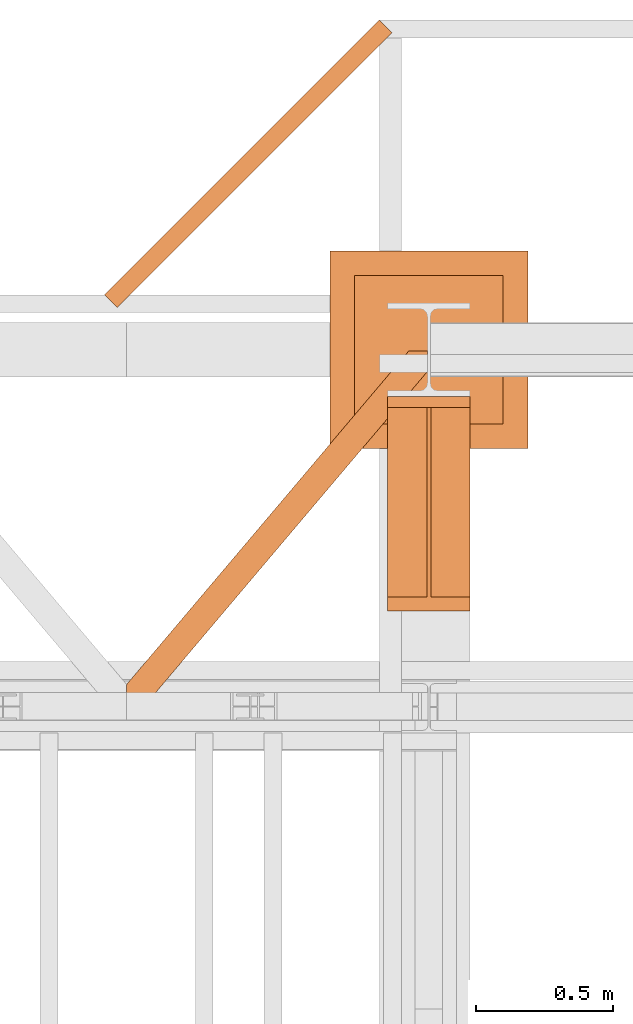
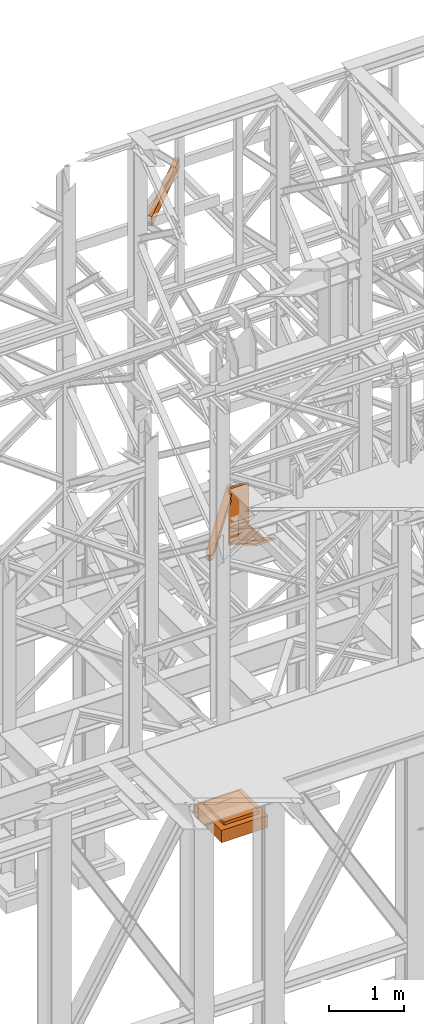
# One storey, part 193 of 208: 4 proxies.
"""IFC2X3 building model written with IfcOpenShell, lengths in millimetres."""

from ifc_helpers import new_model, entity, si_unit, converted_unit, frame, origin, origin_with_axes, place, context, subcontext, project, spatial, faceted_brep, element, save


model = new_model("IFC2X3")

# Units and contexts
model_context = context("Model", 3, precision=1e-05, world=origin())
plan_context = context("Plan", 3, precision=1e-05, world=origin())
body_context = subcontext(model_context, "Body", "Model", "MODEL_VIEW")
ifc_project = project(units=[si_unit("LENGTHUNIT", "METRE", prefix="MILLI"), converted_unit("PLANEANGLEUNIT", "DEGREE", entity("IfcPlaneAngleMeasure", 0.0174532925199433), si_unit("PLANEANGLEUNIT", "RADIAN"), dimensions=[0, 0, 0, 0, 0, 0, 0]), si_unit("AREAUNIT", "SQUARE_METRE"), si_unit("VOLUMEUNIT", "CUBIC_METRE")], contexts=[model_context, plan_context])

# Building, storey
building_placement = place(None, origin())
building = spatial("IfcBuilding", under=ifc_project, at=building_placement, CompositionType="COMPLEX")
storey_placement = place(building_placement, origin_with_axes())
storey = spatial("IfcBuildingStorey", under=building, at=storey_placement, Name="Geschoss", CompositionType="ELEMENT")

# Proxies
proxy_1_placement = place(storey_placement, frame((5343.254974489131, -13412.43639531565, 4367.230005364415), z_axis=(0.0, 0.0, 1.0), x_axis=(1.0, 0.0, 0.0)))
element("IfcBuildingElementProxy", 1, at=proxy_1_placement, inside=storey, context=body_context, shape_type="Brep", body=[
    faceted_brep([(0.01000000000021828, 739.8719999999976, 18.61000000000058), (0.01000000000021828, 0.00999999999839929, 445.7700000000004), (300.0100000000002, 0.00999999999839929, 445.7700000000004), (300.0100000000002, 739.8719999999976, 18.61000000000058), (0.01000000000021828, 0.00999999999839929, 445.7700000000004), (0.01000000000021828, 50.06599999999889, 445.7710000000006), (142.5100000000002, 50.06599999999708, 445.7710000000006), (142.5100000000002, 739.8719999999976, 445.7700000000004), (157.5100000000002, 739.8719999999976, 445.7700000000004), (157.5100000000002, 50.06599999999708, 445.7710000000006), (300.0100000000002, 50.06599999999708, 445.7710000000006), (300.0100000000002, 0.00999999999839929, 445.7700000000004), (0.01000000000021828, 50.06599999999889, 445.7710000000006), (0.01000000000021828, 739.8719999999976, 47.51000000000022), (142.5100000000002, 739.8719999999976, 47.51000000000022), (142.5100000000002, 50.06599999999708, 445.7710000000006), (157.5100000000002, 739.8719999999976, 47.51000000000022), (300.0100000000002, 739.8719999999976, 47.51000000000022), (300.0100000000002, 50.06599999999708, 445.7710000000006), (157.5100000000002, 50.06599999999708, 445.7710000000006), (0.01000000000021828, 739.8719999999976, 18.61000000000058), (0.01000000000021828, 739.8719999999976, 0.01000000000021828), (0.01000000000021828, 779.8719999999976, 0.01000000000021828), (0.01000000000021828, 779.8719999999976, 917.7700000000013), (0.01000000000021828, 739.8719999999976, 917.7700000000013), (0.01000000000021828, 739.8719999999976, 47.51000000000022), (0.01000000000021828, 50.06599999999889, 445.7710000000006), (0.01000000000021828, 0.00999999999839929, 445.7700000000004), (300.0100000000002, 779.8719999999976, 917.7700000000013), (300.0100000000002, 779.8719999999976, 0.01000000000021828), (300.0100000000002, 739.8719999999976, 0.01000000000021828), (300.0100000000002, 739.8719999999976, 18.61000000000058), (300.0100000000002, 0.00999999999839929, 445.7700000000004), (300.0100000000002, 50.06599999999708, 445.7710000000006), (300.0100000000002, 739.8719999999976, 47.51000000000022), (300.0100000000002, 739.8719999999976, 917.7700000000013), (300.0100000000002, 779.8719999999976, 917.7700000000013), (300.0100000000002, 739.8719999999976, 917.7700000000013), (0.01000000000021828, 739.8719999999976, 917.7700000000013), (0.01000000000021828, 779.8719999999976, 917.7700000000013), (300.0100000000002, 739.8719999999976, 917.7700000000013), (300.0100000000002, 739.8719999999976, 47.51000000000022), (157.5100000000002, 739.8719999999976, 47.51000000000022), (157.5100000000002, 739.8719999999976, 445.7700000000004), (142.5100000000002, 739.8719999999976, 445.7700000000004), (142.5100000000002, 739.8719999999976, 47.51000000000022), (0.01000000000021828, 739.8719999999976, 47.51000000000022), (0.01000000000021828, 739.8719999999976, 917.7700000000013), (300.0100000000002, 739.8719999999976, 18.61000000000058), (300.0100000000002, 739.8719999999976, 0.01000000000021828), (0.01000000000021828, 739.8719999999976, 0.01000000000021828), (0.01000000000021828, 739.8719999999976, 18.61000000000058), (300.0100000000002, 739.8719999999976, 0.01000000000021828), (300.0100000000002, 779.8719999999976, 0.01000000000021828), (0.01000000000021828, 779.8719999999976, 0.01000000000021828), (0.01000000000021828, 739.8719999999976, 0.01000000000021828), (300.0100000000002, 779.8719999999976, 0.01000000000021828), (300.0100000000002, 779.8719999999976, 917.7700000000013), (0.01000000000021828, 779.8719999999976, 917.7700000000013), (0.01000000000021828, 779.8719999999976, 0.01000000000021828), (142.5100000000002, 739.8719999999976, 47.51000000000022), (142.5100000000002, 739.8719999999976, 445.7700000000004), (142.5100000000002, 50.06599999999708, 445.7710000000006), (157.5100000000002, 739.8719999999976, 47.51000000000022), (157.5100000000002, 50.06599999999708, 445.7710000000006), (157.5100000000002, 739.8719999999976, 445.7700000000004)], [[[0, 1, 2, 3]], [[4, 5, 6, 7, 8, 9, 10, 11]], [[12, 13, 14, 15]], [[16, 17, 18, 19]], [[20, 21, 22, 23, 24, 25, 26, 27]], [[28, 29, 30, 31, 32, 33, 34, 35]], [[36, 37, 38, 39]], [[40, 41, 42, 43, 44, 45, 46, 47]], [[48, 49, 50, 51]], [[52, 53, 54, 55]], [[56, 57, 58, 59]], [[60, 61, 62]], [[63, 64, 65]]], orient=[[False], [False], [False], [False], [False], [False], [False], [False], [False], [False], [False], [False], [False]]),
])
proxy_2_placement = place(storey_placement, frame((4393.254968528675, -13757.87439038569, 5101.99001616488), z_axis=(0.0, 0.0, 1.0), x_axis=(1.0, 0.0, 0.0)))
element("IfcBuildingElementProxy", 2, at=proxy_2_placement, inside=storey, context=body_context, shape_type="Brep", body=[
    faceted_brep([(65.50764084493949, 0.01000000000021828, 8.010001311303313), (1094.009999947834, 1215.512788030694, 8.010001311302403), (1094.009999947834, 1215.512788030694, 0.01000000000112777), (65.50764084493949, 0.01000000000021828, 0.01000000000112777), (65.50764084493949, 0.01000000000021828, 0.01000000000112777), (1094.009999947834, 1215.512788030694, 0.01000000000112777), (1094.009999947834, 1290.610003345229, 0.01000000000021828), (1026.558515831797, 1290.610003345229, 0.01000000000021828), (0.01000000000294676, 77.4163028167477, 0.01000000000112777), (0.01000000000294676, 0.01000000000021828, 0.01000000000112777), (0.01000000000294676, 77.4163028167477, 0.01000000000112777), (1026.558515831797, 1290.610003345229, 0.01000000000021828), (1026.558515831797, 1290.610003345229, 8.010001311303313), (0.01000000000112777, 77.41630281674588, 8.010001311303313), (0.01000000000112777, 77.41630281674588, 8.010001311303313), (1026.558515831797, 1290.610003345229, 8.010001311303313), (1073.061840441306, 1290.610003345229, 8.010001311303313), (0.01000000000294676, 22.45782827823496, 8.010001311303313), (0.01000000000294676, 22.45782827823496, 8.010001311303313), (1073.061840441306, 1290.610003345229, 8.010001311303313), (1081.197355239431, 1290.610003345229, 9.253033826352294), (0.01000000000203727, 12.84312897136078, 9.253033826352294), (0.01000000000203727, 12.84312897136078, 9.253033826352294), (1081.197355239431, 1290.610003345229, 9.253033826352294), (1087.152961141162, 1290.610003345229, 13.79946006298178), (0.01000000000203727, 5.804685632951077, 13.79946006298178), (0.01000000000203727, 5.804685632951077, 13.79946006298178), (1087.152961141162, 1290.610003345229, 13.79946006298178), (1088.781274451488, 1290.610003345229, 20.01000141561144), (0.01000000000294676, 3.880315357111613, 20.01000141561144), (0.01000000000294676, 3.880315357111613, 20.01000141561144), (1088.781274451488, 1290.610003345229, 20.01000141561144), (1088.781274451488, 1290.610003345229, 76.01000128150099), (0.01000000000294676, 3.880315357111613, 76.01000128150099), (0.01000000000294676, 3.880315357111613, 76.01000128150099), (1088.781274451488, 1290.610003345229, 76.01000128150099), (1087.152961141162, 1290.610003345229, 82.2205407714855), (0.01000000000203727, 5.804685632951077, 82.2205407714855), (0.01000000000203727, 5.804685632951077, 82.2205407714855), (1087.152961141162, 1290.610003345229, 82.2205407714855), (1081.197355239431, 1290.610003345229, 86.76696700811499), (0.01000000000203727, 12.84312897136078, 86.76696700811499), (0.01000000000203727, 12.84312897136078, 86.76696700811499), (1081.197355239431, 1290.610003345229, 86.76696700811499), (1073.061840441305, 1290.610003345229, 88.00999952316397), (0.01000000000203727, 22.45782827823496, 88.00999952316397), (0.01000000000203727, 22.45782827823496, 88.00999952316397), (1073.061840441305, 1290.610003345229, 88.00999952316397), (1026.558515831796, 1290.610003345229, 88.00999952316397), (0.01000000000294676, 77.4163028167477, 88.00999952316397), (0.01000000000294676, 77.4163028167477, 88.00999952316397), (1026.558515831796, 1290.610003345229, 88.00999952316397), (1026.558515831796, 1290.610003345229, 96.01000083446615), (0.01000000000021828, 77.41630281674406, 96.01000083446615), (0.01000000000021828, 77.41630281674406, 96.01000083446615), (1026.558515831796, 1290.610003345229, 96.01000083446615), (1094.009999947834, 1290.610003345229, 96.01000083446615), (1094.009999947834, 1215.512788030694, 96.01000083446615), (65.50764084493858, 0.01000000000021828, 96.01000083446615), (0.01000000000112777, 0.01000000000021828, 96.01000083446615), (65.50764084493858, 0.01000000000021828, 96.01000083446615), (1094.009999947834, 1215.512788030694, 96.01000083446615), (1094.009999947834, 1215.512788030694, 88.00999952316397), (65.50764084493858, 0.01000000000021828, 88.00999952316397), (65.50764084493858, 0.01000000000021828, 88.00999952316397), (1094.009999947834, 1215.512788030694, 88.00999952316397), (1094.009999947834, 1270.471262569208, 88.00999952316397), (19.00431623542772, 0.01000000000021828, 88.00999952316397), (19.00431623542772, 0.01000000000021828, 88.00999952316397), (1094.009999947834, 1270.471262569208, 88.00999952316397), (1094.009999947834, 1280.085961876084, 86.76696700811499), (10.86880143730195, 0.01000000000021828, 86.76696700811499), (10.86880143730195, 0.01000000000021828, 86.76696700811499), (1094.009999947834, 1280.085961876084, 86.76696700811499), (1094.009999947834, 1287.12440521449, 82.2205407714855), (4.913195535572413, 0.01000000000021828, 82.2205407714855), (4.913195535572413, 0.01000000000021828, 82.2205407714855), (1094.009999947834, 1287.12440521449, 82.2205407714855), (1094.009999947834, 1289.048775490332, 76.01000128150099), (3.284882225245383, 0.01000000000021828, 76.01000128150099), (3.284882225245383, 0.01000000000021828, 76.01000128150099), (1094.009999947834, 1289.048775490332, 76.01000128150099), (1094.009999947834, 1289.048775490332, 20.01000141561144), (3.284882225246292, 0.01000000000021828, 20.01000141561144), (3.284882225246292, 0.01000000000021828, 20.01000141561144), (1094.009999947834, 1289.048775490332, 20.01000141561144), (1094.009999947835, 1287.12440521449, 13.79946006298178), (4.913195535572413, 0.01000000000021828, 13.79946006298178), (4.913195535572413, 0.01000000000021828, 13.79946006298178), (1094.009999947835, 1287.12440521449, 13.79946006298178), (1094.009999947834, 1280.085961876081, 9.253033826352294), (10.86880143730286, 0.01000000000021828, 9.253033826352294), (10.86880143730286, 0.01000000000021828, 9.253033826352294), (1094.009999947834, 1280.085961876081, 9.253033826352294), (1094.009999947834, 1270.471262569208, 8.010001311303313), (19.00431623542954, 0.01000000000021828, 8.010001311303313), (19.00431623542954, 0.01000000000021828, 8.010001311303313), (1094.009999947834, 1270.471262569208, 8.010001311303313), (1094.009999947834, 1215.512788030694, 8.010001311302403), (65.50764084493949, 0.01000000000021828, 8.010001311303313), (0.01000000000294676, 77.4163028167477, 0.01000000000112777), (0.01000000000112777, 77.41630281674588, 8.010001311303313), (0.01000000000294676, 22.45782827823496, 8.010001311303313), (0.01000000000203727, 12.84312897136078, 9.253033826352294), (0.01000000000203727, 5.804685632951077, 13.79946006298178), (0.01000000000294676, 3.880315357111613, 20.01000141561144), (0.01000000000294676, 3.880315357111613, 76.01000128150099), (0.01000000000203727, 5.804685632951077, 82.2205407714855), (0.01000000000203727, 12.84312897136078, 86.76696700811499), (0.01000000000203727, 22.45782827823496, 88.00999952316397), (0.01000000000294676, 77.4163028167477, 88.00999952316397), (0.01000000000021828, 77.41630281674406, 96.01000083446615), (0.01000000000112777, 0.01000000000021828, 96.01000083446615), (0.01000000000294676, 0.01000000000021828, 0.01000000000112777), (0.01000000000112777, 0.01000000000021828, 96.01000083446615), (65.50764084493858, 0.01000000000021828, 96.01000083446615), (65.50764084493858, 0.01000000000021828, 88.00999952316397), (19.00431623542772, 0.01000000000021828, 88.00999952316397), (10.86880143730195, 0.01000000000021828, 86.76696700811499), (4.913195535572413, 0.01000000000021828, 82.2205407714855), (3.284882225245383, 0.01000000000021828, 76.01000128150099), (3.284882225246292, 0.01000000000021828, 20.01000141561144), (4.913195535572413, 0.01000000000021828, 13.79946006298178), (10.86880143730286, 0.01000000000021828, 9.253033826352294), (19.00431623542954, 0.01000000000021828, 8.010001311303313), (65.50764084493949, 0.01000000000021828, 8.010001311303313), (65.50764084493949, 0.01000000000021828, 0.01000000000112777), (0.01000000000294676, 0.01000000000021828, 0.01000000000112777), (1094.009999947834, 1215.512788030694, 8.010001311302403), (1094.009999947834, 1270.471262569208, 8.010001311303313), (1094.009999947834, 1280.085961876081, 9.253033826352294), (1094.009999947835, 1287.12440521449, 13.79946006298178), (1094.009999947834, 1289.048775490332, 20.01000141561144), (1094.009999947834, 1289.048775490332, 76.01000128150099), (1094.009999947834, 1287.12440521449, 82.2205407714855), (1094.009999947834, 1280.085961876084, 86.76696700811499), (1094.009999947834, 1270.471262569208, 88.00999952316397), (1094.009999947834, 1215.512788030694, 88.00999952316397), (1094.009999947834, 1215.512788030694, 96.01000083446615), (1094.009999947834, 1290.610003345229, 96.01000083446615), (1094.009999947834, 1290.610003345229, 0.01000000000021828), (1094.009999947834, 1215.512788030694, 0.01000000000112777), (1094.009999947834, 1290.610003345229, 0.01000000000021828), (1094.009999947834, 1290.610003345229, 96.01000083446615), (1026.558515831796, 1290.610003345229, 96.01000083446615), (1026.558515831796, 1290.610003345229, 88.00999952316397), (1073.061840441305, 1290.610003345229, 88.00999952316397), (1081.197355239431, 1290.610003345229, 86.76696700811499), (1087.152961141162, 1290.610003345229, 82.2205407714855), (1088.781274451488, 1290.610003345229, 76.01000128150099), (1088.781274451488, 1290.610003345229, 20.01000141561144), (1087.152961141162, 1290.610003345229, 13.79946006298178), (1081.197355239431, 1290.610003345229, 9.253033826352294), (1073.061840441306, 1290.610003345229, 8.010001311303313), (1026.558515831797, 1290.610003345229, 8.010001311303313), (1026.558515831797, 1290.610003345229, 0.01000000000021828)], [[[0, 1, 2, 3]], [[4, 5, 6, 7, 8, 9]], [[10, 11, 12, 13]], [[14, 15, 16, 17]], [[18, 19, 20, 21]], [[22, 23, 24, 25]], [[26, 27, 28, 29]], [[30, 31, 32, 33]], [[34, 35, 36, 37]], [[38, 39, 40, 41]], [[42, 43, 44, 45]], [[46, 47, 48, 49]], [[50, 51, 52, 53]], [[54, 55, 56, 57, 58, 59]], [[60, 61, 62, 63]], [[64, 65, 66, 67]], [[68, 69, 70, 71]], [[72, 73, 74, 75]], [[76, 77, 78, 79]], [[80, 81, 82, 83]], [[84, 85, 86, 87]], [[88, 89, 90, 91]], [[92, 93, 94, 95]], [[96, 97, 98, 99]], [[100, 101, 102, 103, 104, 105, 106, 107, 108, 109, 110, 111, 112, 113]], [[114, 115, 116, 117, 118, 119, 120, 121, 122, 123, 124, 125, 126, 127]], [[128, 129, 130, 131, 132, 133, 134, 135, 136, 137, 138, 139, 140, 141]], [[142, 143, 144, 145, 146, 147, 148, 149, 150, 151, 152, 153, 154, 155]]], orient=[[False], [False], [False], [False], [False], [False], [False], [False], [False], [False], [False], [False], [False], [False], [False], [False], [False], [False], [False], [False], [False], [False], [False], [False], [False], [False], [False], [False]]),
])
proxy_3_placement = place(storey_placement, frame((5133.254968528667, -12822.57439725281, -315.0099999999999), z_axis=(0.0, 0.0, 1.0), x_axis=(1.0, 0.0, 0.0)))
element("IfcBuildingElementProxy", 3, at=proxy_3_placement, inside=storey, context=body_context, shape_type="Brep", body=[
    faceted_brep([(630.0100000000002, 630.0100000000002, 250.01), (630.0100000000002, 90.01000000000022, 250.01), (90.01000000000022, 90.01000000000022, 250.01), (90.01000000000022, 630.0100000000002, 250.01), (630.0100000000002, 630.0100000000002, 200.01), (630.0100000000002, 90.01000000000022, 200.01), (630.0100000000002, 90.01000000000022, 250.01), (630.0100000000002, 630.0100000000002, 250.01), (90.01000000000022, 630.0100000000002, 200.01), (630.0100000000002, 630.0100000000002, 200.01), (630.0100000000002, 630.0100000000002, 250.01), (90.01000000000022, 630.0100000000002, 250.01), (90.01000000000022, 90.01000000000022, 200.01), (90.01000000000022, 630.0100000000002, 200.01), (90.01000000000022, 630.0100000000002, 250.01), (90.01000000000022, 90.01000000000022, 250.01), (630.0100000000002, 90.01000000000022, 200.01), (90.01000000000022, 90.01000000000022, 200.01), (90.01000000000022, 90.01000000000022, 250.01), (630.0100000000002, 90.01000000000022, 250.01), (720.0100000000002, 0.01000000000021828, 0.009999999999990905), (720.0100000000002, 720.0100000000002, 0.009999999999990905), (0.01000000000021828, 720.0100000000002, 0.009999999999990905), (0.01000000000021828, 0.01000000000021828, 0.009999999999990905), (720.0100000000002, 720.0100000000002, 200.01), (720.0100000000002, 0.01000000000021828, 200.01), (0.01000000000021828, 0.01000000000021828, 200.01), (0.01000000000021828, 720.0100000000002, 200.01), (90.01000000000022, 90.01000000000022, 200.01), (630.0100000000002, 90.01000000000022, 200.01), (630.0100000000002, 630.0100000000002, 200.01), (90.01000000000022, 630.0100000000002, 200.01), (720.0100000000002, 720.0100000000002, 0.009999999999990905), (720.0100000000002, 0.01000000000021828, 0.009999999999990905), (720.0100000000002, 0.01000000000021828, 200.01), (720.0100000000002, 720.0100000000002, 200.01), (0.01000000000021828, 720.0100000000002, 0.009999999999990905), (720.0100000000002, 720.0100000000002, 0.009999999999990905), (720.0100000000002, 720.0100000000002, 200.01), (0.01000000000021828, 720.0100000000002, 200.01), (0.01000000000021828, 0.01000000000021828, 0.009999999999990905), (0.01000000000021828, 720.0100000000002, 0.009999999999990905), (0.01000000000021828, 720.0100000000002, 200.01), (0.01000000000021828, 0.01000000000021828, 200.01), (720.0100000000002, 0.01000000000021828, 0.009999999999990905), (0.01000000000021828, 0.01000000000021828, 0.009999999999990905), (0.01000000000021828, 0.01000000000021828, 200.01), (720.0100000000002, 0.01000000000021828, 200.01)], [[[0, 1, 2, 3]], [[4, 5, 6, 7]], [[8, 9, 10, 11]], [[12, 13, 14, 15]], [[16, 17, 18, 19]], [[20, 21, 22, 23]], [[24, 25, 26, 27], [28, 29, 30, 31]], [[32, 33, 34, 35]], [[36, 37, 38, 39]], [[40, 41, 42, 43]], [[44, 45, 46, 47]]], orient=[[False], [False], [False], [False], [False], [False], [False, False], [False], [False], [False], [False]]),
])
proxy_4_placement = place(storey_placement, frame((4313.254967038553, -12308.5363296049, 9699.99), z_axis=(0.0, 0.0, 1.0), x_axis=(1.0, 0.0, 0.0)))
element("IfcBuildingElementProxy", 4, at=proxy_4_placement, inside=storey, context=body_context, shape_type="Brep", body=[
    faceted_brep([(0.01000000000021828, 45.97194077712811, 0.01000000000021828), (1000.009999999998, 1045.971940777128, 0.01000000000021828), (1000.009999999998, 1045.971940777128, 3.132428070246533), (0.01000000000021828, 45.97194077712811, 3.132428070246533), (0.01000000000021828, 45.97194077712811, 3.132428070246533), (1000.009999999998, 1045.971940777128, 3.132428070246533), (1000.181640679759, 1045.800300097368, 4.748288908171162), (0.181640679760676, 45.80030009736402, 4.748288908171162), (0.181640679760676, 45.80030009736402, 4.748288908171162), (1000.181640679759, 1045.800300097368, 4.748288908171162), (1000.681375059186, 1045.30056571794, 6.221534443444398), (0.6813750591882126, 45.30056571794012, 6.221534443444398), (0.6813750591882126, 45.30056571794012, 6.221534443444398), (1000.681375059186, 1045.30056571794, 6.221534443444398), (1001.46511853109, 1044.516822246036, 7.422126703873801), (1.46511853109223, 44.5168222460361, 7.422126703873801), (1.46511853109223, 44.5168222460361, 7.422126703873801), (1001.46511853109, 1044.516822246036, 7.422126703873801), (1002.46369135245, 1043.518249424677, 8.244091391710754), (2.46369135245186, 43.51824942467465, 8.244091391710754), (2.46369135245186, 43.51824942467465, 8.244091391710754), (1002.46369135245, 1043.518249424677, 8.244091391710754), (1003.588951165584, 1042.392989611542, 8.614912102195376), (3.588951165585968, 42.39298961153872, 8.614912102195376), (3.588951165585968, 42.39298961153872, 8.614912102195376), (1003.588951165584, 1042.392989611542, 8.614912102195376), (1033.836096783922, 1012.145843993205, 12.0369859867169), (33.8360967839235, 12.1458439932012, 12.0369859867169), (33.8360967839235, 12.1458439932012, 12.0369859867169), (1033.836096783922, 1012.145843993205, 12.0369859867169), (1035.984320063542, 1009.997620713582, 12.74491643400506), (35.98432006354415, 9.997620713582364, 12.74491643400506), (35.98432006354415, 9.997620713582364, 12.74491643400506), (1035.984320063542, 1009.997620713582, 12.74491643400506), (1037.890686358867, 1008.091254418259, 14.31412174714933), (37.89068635886724, 8.091254418259268, 14.31412174714933), (37.89068635886724, 8.091254418259268, 14.31412174714933), (1037.890686358867, 1008.091254418259, 14.31412174714933), (1039.386923896138, 1006.595016880989, 16.60616151705835), (39.38692389613789, 6.595016880988624, 16.60616151705835), (39.38692389613789, 6.595016880988624, 16.60616151705835), (1039.386923896138, 1006.595016880989, 16.60616151705835), (1040.340962256862, 1005.640978520265, 19.41872117530875), (40.34096225686335, 5.640978520261342, 19.41872117530875), (40.34096225686335, 5.640978520261342, 19.41872117530875), (1040.340962256862, 1005.640978520265, 19.41872117530875), (1040.668639918225, 1005.313300858901, 22.50354641134618), (40.66863991822538, 5.31330085890113, 22.50354641134618), (40.66863991822538, 5.31330085890113, 22.50354641134618), (1040.668639918225, 1005.313300858901, 22.50354641134618), (1040.668639918225, 1005.313300858901, 137.5164535886524), (40.66863991822538, 5.31330085890113, 137.5164535886524), (40.66863991822538, 5.31330085890113, 137.5164535886524), (1040.668639918225, 1005.313300858901, 137.5164535886524), (1040.340962256862, 1005.640978520265, 140.6012788246917), (40.34096225686335, 5.640978520261342, 140.6012788246917), (40.34096225686335, 5.640978520261342, 140.6012788246917), (1040.340962256862, 1005.640978520265, 140.6012788246917), (1039.386923896138, 1006.595016880989, 143.4138384829403), (39.38692389613789, 6.595016880988624, 143.4138384829403), (39.38692389613789, 6.595016880988624, 143.4138384829403), (1039.386923896138, 1006.595016880989, 143.4138384829403), (1037.890686358867, 1008.091254418259, 145.7058782528493), (37.89068635886724, 8.091254418259268, 145.7058782528493), (37.89068635886724, 8.091254418259268, 145.7058782528493), (1037.890686358867, 1008.091254418259, 145.7058782528493), (1035.984320063542, 1009.997620713582, 147.2750835659936), (35.98432006354415, 9.997620713582364, 147.2750835659936), (35.98432006354415, 9.997620713582364, 147.2750835659936), (1035.984320063542, 1009.997620713582, 147.2750835659936), (1033.836096783922, 1012.145843993205, 147.9830140132817), (33.8360967839235, 12.1458439932012, 147.9830140132817), (33.8360967839235, 12.1458439932012, 147.9830140132817), (1033.836096783922, 1012.145843993205, 147.9830140132817), (1003.588951165584, 1042.392989611542, 151.4050878978032), (3.588951165585968, 42.39298961153872, 151.4050878978032), (3.588951165585968, 42.39298961153872, 151.4050878978032), (1003.588951165584, 1042.392989611542, 151.4050878978032), (1002.46369135245, 1043.518249424677, 151.7759086082879), (2.46369135245186, 43.51824942467465, 151.7759086082879), (2.46369135245186, 43.51824942467465, 151.7759086082879), (1002.46369135245, 1043.518249424677, 151.7759086082879), (1001.46511853109, 1044.516822246036, 152.5978732961248), (1.46511853109223, 44.5168222460361, 152.5978732961248), (1.46511853109223, 44.5168222460361, 152.5978732961248), (1001.46511853109, 1044.516822246036, 152.5978732961248), (1000.681375059186, 1045.30056571794, 153.7984655565542), (0.6813750591882126, 45.30056571794012, 153.7984655565542), (0.6813750591882126, 45.30056571794012, 153.7984655565542), (1000.681375059186, 1045.30056571794, 153.7984655565542), (1000.181640679759, 1045.800300097368, 155.2717110918275), (0.181640679760676, 45.80030009736402, 155.2717110918275), (0.181640679760676, 45.80030009736402, 155.2717110918275), (1000.181640679759, 1045.800300097368, 155.2717110918275), (1000.009999999998, 1045.971940777128, 156.8875719297521), (0.01000000000021828, 45.97194077712811, 156.8875719297521), (0.01000000000021828, 45.97194077712811, 156.8875719297521), (1000.009999999998, 1045.971940777128, 156.8875719297521), (1000.009999999998, 1045.971940777128, 160.0100000000002), (0.01000000000021828, 45.97194077712811, 160.0100000000002), (0.01000000000021828, 45.97194077712811, 160.0100000000002), (1000.009999999998, 1045.971940777128, 160.0100000000002), (1045.971940777125, 1000.010000000004, 160.0100000000002), (45.97194077712447, 0.01000000000021828, 160.0100000000002), (45.97194077712447, 0.01000000000021828, 160.0100000000002), (1045.971940777125, 1000.010000000004, 160.0100000000002), (1045.971940777125, 1000.010000000004, 0.01000000000021828), (45.97194077712447, 0.01000000000021828, 0.01000000000021828), (45.97194077712447, 0.01000000000021828, 0.01000000000021828), (1045.971940777125, 1000.010000000004, 0.01000000000021828), (1000.009999999998, 1045.971940777128, 0.01000000000021828), (0.01000000000021828, 45.97194077712811, 0.01000000000021828), (0.01000000000021828, 45.97194077712811, 0.01000000000021828), (0.01000000000021828, 45.97194077712811, 3.132428070246533), (0.181640679760676, 45.80030009736402, 4.748288908171162), (0.6813750591882126, 45.30056571794012, 6.221534443444398), (1.46511853109223, 44.5168222460361, 7.422126703873801), (2.46369135245186, 43.51824942467465, 8.244091391710754), (3.588951165585968, 42.39298961153872, 8.614912102195376), (33.8360967839235, 12.1458439932012, 12.0369859867169), (35.98432006354415, 9.997620713582364, 12.74491643400506), (37.89068635886724, 8.091254418259268, 14.31412174714933), (39.38692389613789, 6.595016880988624, 16.60616151705835), (40.34096225686335, 5.640978520261342, 19.41872117530875), (40.66863991822538, 5.31330085890113, 22.50354641134618), (40.66863991822538, 5.31330085890113, 137.5164535886524), (40.34096225686335, 5.640978520261342, 140.6012788246917), (39.38692389613789, 6.595016880988624, 143.4138384829403), (37.89068635886724, 8.091254418259268, 145.7058782528493), (35.98432006354415, 9.997620713582364, 147.2750835659936), (33.8360967839235, 12.1458439932012, 147.9830140132817), (3.588951165585968, 42.39298961153872, 151.4050878978032), (2.46369135245186, 43.51824942467465, 151.7759086082879), (1.46511853109223, 44.5168222460361, 152.5978732961248), (0.6813750591882126, 45.30056571794012, 153.7984655565542), (0.181640679760676, 45.80030009736402, 155.2717110918275), (0.01000000000021828, 45.97194077712811, 156.8875719297521), (0.01000000000021828, 45.97194077712811, 160.0100000000002), (45.97194077712447, 0.01000000000021828, 160.0100000000002), (45.97194077712447, 0.01000000000021828, 0.01000000000021828), (1000.009999999998, 1045.971940777128, 0.01000000000021828), (1045.971940777125, 1000.010000000004, 0.01000000000021828), (1045.971940777125, 1000.010000000004, 160.0100000000002), (1000.009999999998, 1045.971940777128, 160.0100000000002), (1000.009999999998, 1045.971940777128, 156.8875719297521), (1000.181640679759, 1045.800300097368, 155.2717110918275), (1000.681375059186, 1045.30056571794, 153.7984655565542), (1001.46511853109, 1044.516822246036, 152.5978732961248), (1002.46369135245, 1043.518249424677, 151.7759086082879), (1003.588951165584, 1042.392989611542, 151.4050878978032), (1033.836096783922, 1012.145843993205, 147.9830140132817), (1035.984320063542, 1009.997620713582, 147.2750835659936), (1037.890686358867, 1008.091254418259, 145.7058782528493), (1039.386923896138, 1006.595016880989, 143.4138384829403), (1040.340962256862, 1005.640978520265, 140.6012788246917), (1040.668639918225, 1005.313300858901, 137.5164535886524), (1040.668639918225, 1005.313300858901, 22.50354641134618), (1040.340962256862, 1005.640978520265, 19.41872117530875), (1039.386923896138, 1006.595016880989, 16.60616151705835), (1037.890686358867, 1008.091254418259, 14.31412174714933), (1035.984320063542, 1009.997620713582, 12.74491643400506), (1033.836096783922, 1012.145843993205, 12.0369859867169), (1003.588951165584, 1042.392989611542, 8.614912102195376), (1002.46369135245, 1043.518249424677, 8.244091391710754), (1001.46511853109, 1044.516822246036, 7.422126703873801), (1000.681375059186, 1045.30056571794, 6.221534443444398), (1000.181640679759, 1045.800300097368, 4.748288908171162), (1000.009999999998, 1045.971940777128, 3.132428070246533)], [[[0, 1, 2, 3]], [[4, 5, 6, 7]], [[8, 9, 10, 11]], [[12, 13, 14, 15]], [[16, 17, 18, 19]], [[20, 21, 22, 23]], [[24, 25, 26, 27]], [[28, 29, 30, 31]], [[32, 33, 34, 35]], [[36, 37, 38, 39]], [[40, 41, 42, 43]], [[44, 45, 46, 47]], [[48, 49, 50, 51]], [[52, 53, 54, 55]], [[56, 57, 58, 59]], [[60, 61, 62, 63]], [[64, 65, 66, 67]], [[68, 69, 70, 71]], [[72, 73, 74, 75]], [[76, 77, 78, 79]], [[80, 81, 82, 83]], [[84, 85, 86, 87]], [[88, 89, 90, 91]], [[92, 93, 94, 95]], [[96, 97, 98, 99]], [[100, 101, 102, 103]], [[104, 105, 106, 107]], [[108, 109, 110, 111]], [[112, 113, 114, 115, 116, 117, 118, 119, 120, 121, 122, 123, 124, 125, 126, 127, 128, 129, 130, 131, 132, 133, 134, 135, 136, 137, 138, 139]], [[140, 141, 142, 143, 144, 145, 146, 147, 148, 149, 150, 151, 152, 153, 154, 155, 156, 157, 158, 159, 160, 161, 162, 163, 164, 165, 166, 167]]], orient=[[False], [False], [False], [False], [False], [False], [False], [False], [False], [False], [False], [False], [False], [False], [False], [False], [False], [False], [False], [False], [False], [False], [False], [False], [False], [False], [False], [False], [False], [False]]),
])

save(model, "model.ifc")
